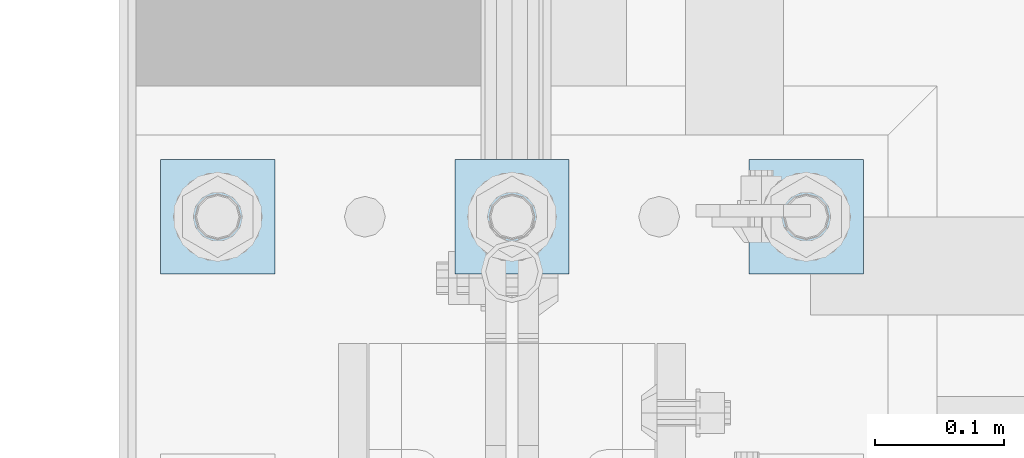
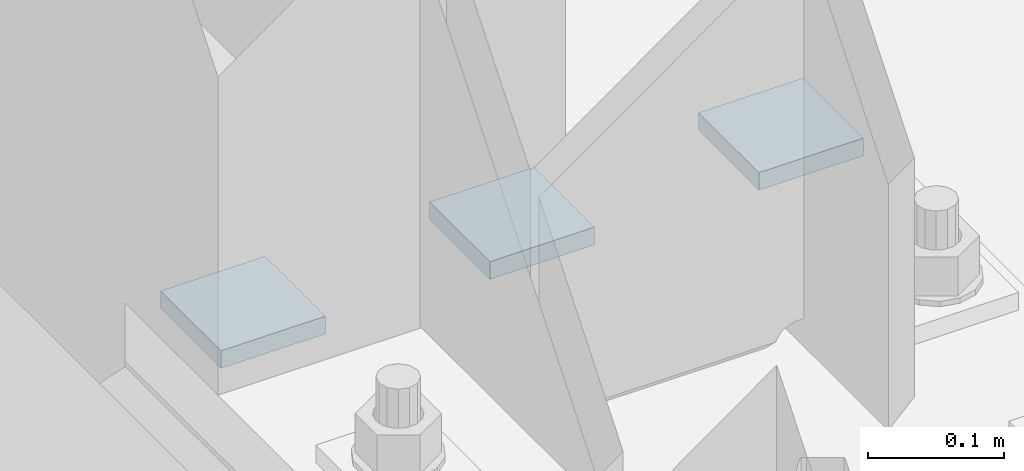
# One storey, part 1427 of 1876: 3 plates, 1 element without a shape of its own.
"""IFC2X3 building model written with IfcOpenShell, lengths in millimetres."""

from ifc_helpers import new_model, si_unit, frame, origin_with_axes, place, context, subcontext, project, spatial, faceted_brep, material, type_object, element, aggregate, save


model = new_model("IFC2X3")

# Units and contexts
model_context = context("Model", 3, precision=1e-05, world=origin_with_axes())
body_context = subcontext(model_context, "Body", "Model", "MODEL_VIEW")
ifc_project = project(units=[si_unit("LENGTHUNIT", "METRE", prefix="MILLI"), si_unit("AREAUNIT", "SQUARE_METRE"), si_unit("VOLUMEUNIT", "CUBIC_METRE"), si_unit("MASSUNIT", "GRAM", prefix="KILO"), si_unit("TIMEUNIT", "SECOND"), si_unit("PLANEANGLEUNIT", "RADIAN"), si_unit("SOLIDANGLEUNIT", "STERADIAN"), si_unit("THERMODYNAMICTEMPERATUREUNIT", "DEGREE_CELSIUS"), si_unit("LUMINOUSINTENSITYUNIT", "LUMEN")], contexts=[model_context])

# Site, building, storey
site_placement = place(None, origin_with_axes())
site = spatial("IfcSite", under=ifc_project, at=site_placement, CompositionType="ELEMENT")
building_placement = place(site_placement, origin_with_axes())
building = spatial("IfcBuilding", under=site, at=building_placement, Name="Undefined", CompositionType="ELEMENT")
storey_placement = place(building_placement, origin_with_axes())
storey = spatial("IfcBuildingStorey", under=building, at=storey_placement, Name="Undefined", CompositionType="ELEMENT", Elevation=0.0)

# Assembly, plates
assembly_placement = place(storey_placement, origin_with_axes())
assembly = element("IfcElementAssembly", 1, at=assembly_placement, inside=storey, Name="TEMPLATE", AssemblyPlace="NOTDEFINED", PredefinedType="RIGID_FRAME")
ifc_material = material(Name="STEEL/A572-50")
plate_type = type_object("IfcPlateType", PredefinedType="NOTDEFINED")
plate_1_placement = place(assembly_placement, frame((184.15, -6838.95, 103.1875), z_axis=(0.0, -1.0, 0.0), x_axis=(1.0, 0.0, 0.0)))
plate_1 = element("IfcPlate", 2, at=plate_1_placement, type_object=plate_type, material=ifc_material, Name="PLATE WASHER", context=body_context, shape_type="Brep", body=[
    faceted_brep([(0.0, -7.9375, 0.0), (0.0, -7.9375, 88.9000015258789), (0.0, 7.9375, 88.9000015258789), (0.0, 7.9375, 0.0), (88.9000015258789, -7.9375, 88.9000015258789), (88.9000015258789, 7.9375, 88.9000015258789), (88.9000015258789, -7.9375, 0.0), (88.9000015258789, 7.9375, 0.0)], [[[0, 1, 2, 3]], [[1, 4, 5, 2]], [[4, 6, 7, 5]], [[6, 0, 3, 7]], [[5, 7, 3, 2]], [[6, 4, 1, 0]]]),
])
plate_2_placement = place(assembly_placement, frame((-44.4500000000001, -6838.95, 103.1875), z_axis=(0.0, -1.0, 0.0), x_axis=(1.0, 0.0, 0.0)))
plate_2 = element("IfcPlate", 3, at=plate_2_placement, type_object=plate_type, material=ifc_material, Name="PLATE WASHER", context=body_context, shape_type="Brep", body=[
    faceted_brep([(0.0, -7.9375, 0.0), (0.0, -7.9375, 88.9000015258789), (0.0, 7.9375, 88.9000015258789), (0.0, 7.9375, 0.0), (88.9000015258789, -7.9375, 88.9000015258789), (88.9000015258789, 7.9375, 88.9000015258789), (88.9000015258789, -7.9375, 0.0), (88.9000015258789, 7.9375, 0.0)], [[[0, 1, 2, 3]], [[1, 4, 5, 2]], [[4, 6, 7, 5]], [[6, 0, 3, 7]], [[5, 7, 3, 2]], [[6, 4, 1, 0]]]),
])
plate_3_placement = place(assembly_placement, frame((-273.05, -6838.95, 103.1875), z_axis=(0.0, -1.0, 0.0), x_axis=(1.0, 0.0, 0.0)))
plate_3 = element("IfcPlate", 4, at=plate_3_placement, type_object=plate_type, material=ifc_material, Name="PLATE WASHER", context=body_context, shape_type="Brep", body=[
    faceted_brep([(0.0, -7.9375, 0.0), (0.0, -7.9375, 88.9000015258789), (0.0, 7.9375, 88.9000015258789), (0.0, 7.9375, 0.0), (88.9000015258789, -7.9375, 88.9000015258789), (88.9000015258789, 7.9375, 88.9000015258789), (88.9000015258789, -7.9375, 0.0), (88.9000015258789, 7.9375, 0.0)], [[[0, 1, 2, 3]], [[1, 4, 5, 2]], [[4, 6, 7, 5]], [[6, 0, 3, 7]], [[5, 7, 3, 2]], [[6, 4, 1, 0]]]),
])
aggregate(assembly, [plate_1, plate_2, plate_3])

save(model, "model.ifc")
